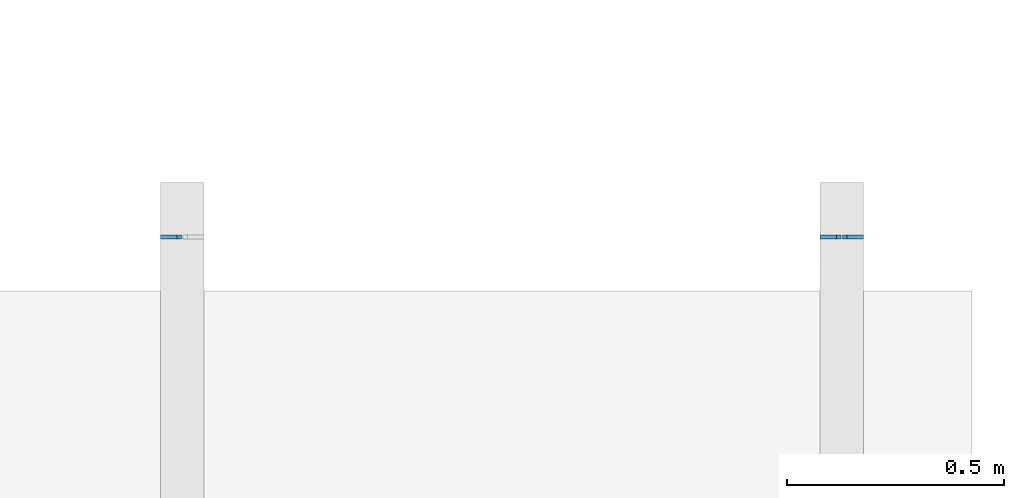
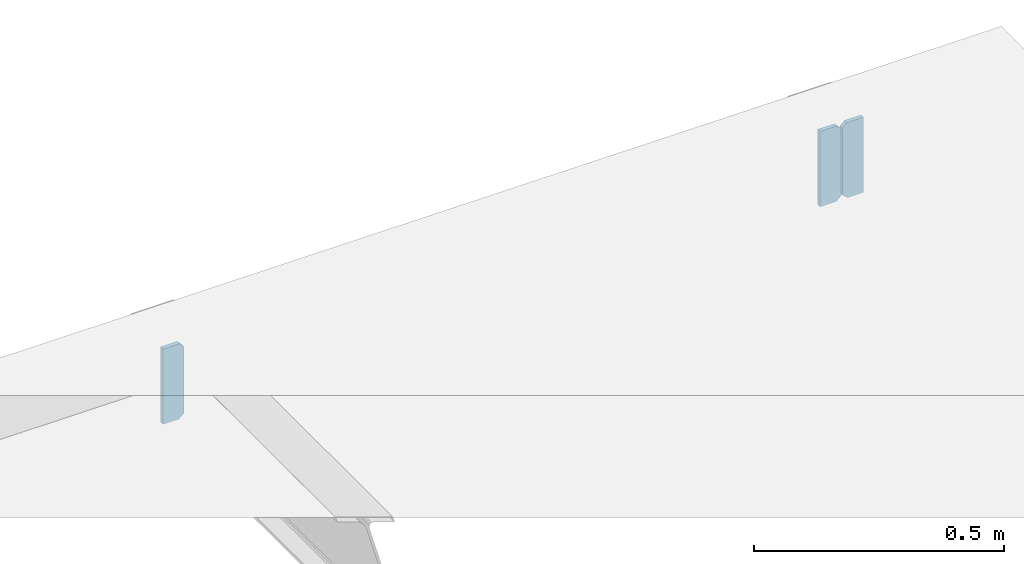
# One storey, part 6 of 7: 3 beams.
"""IFC2X3 building model written with IfcOpenShell, lengths in millimetres."""

from ifc_helpers import new_model, entity, si_unit, converted_unit, derived_unit, money_unit, direction, frame, origin_with_axes, place, context, subcontext, project, spatial, faceted_brep, material, type_object, element, save


model = new_model("IFC2X3")

# Units and contexts
model_context = context("Model", 3, precision=1e-05, world=origin_with_axes(), true_north=direction((0.0, 1.0)))
body_context = subcontext(model_context, "Body", "Model", "MODEL_VIEW", scale=1.0)
ifc_project = project(units=[si_unit("LENGTHUNIT", "METRE", prefix="MILLI"), si_unit("AREAUNIT", "SQUARE_METRE"), si_unit("VOLUMEUNIT", "CUBIC_METRE"), si_unit("ABSORBEDDOSEUNIT", "GRAY"), si_unit("AMOUNTOFSUBSTANCEUNIT", "MOLE"), si_unit("DOSEEQUIVALENTUNIT", "SIEVERT"), si_unit("ELECTRICCAPACITANCEUNIT", "FARAD"), si_unit("ELECTRICCHARGEUNIT", "COULOMB"), si_unit("ELECTRICCONDUCTANCEUNIT", "SIEMENS"), si_unit("ELECTRICCURRENTUNIT", "AMPERE"), si_unit("ELECTRICRESISTANCEUNIT", "OHM"), si_unit("ELECTRICVOLTAGEUNIT", "VOLT"), si_unit("ENERGYUNIT", "JOULE"), si_unit("FORCEUNIT", "NEWTON"), si_unit("FREQUENCYUNIT", "HERTZ"), si_unit("ILLUMINANCEUNIT", "LUX"), si_unit("INDUCTANCEUNIT", "HENRY"), si_unit("LUMINOUSFLUXUNIT", "LUMEN"), si_unit("LUMINOUSINTENSITYUNIT", "CANDELA"), si_unit("MAGNETICFLUXDENSITYUNIT", "TESLA"), si_unit("MAGNETICFLUXUNIT", "WEBER"), si_unit("MASSUNIT", "GRAM"), converted_unit("PLANEANGLEUNIT", "degree", entity("IfcReal", 0.0174532925199433), si_unit("PLANEANGLEUNIT", "RADIAN"), dimensions=[0, 0, 0, 0, 0, 0, 0]), si_unit("POWERUNIT", "WATT"), si_unit("PRESSUREUNIT", "PASCAL"), si_unit("RADIOACTIVITYUNIT", "BECQUEREL"), si_unit("SOLIDANGLEUNIT", "STERADIAN"), si_unit("THERMODYNAMICTEMPERATUREUNIT", "KELVIN"), si_unit("TIMEUNIT", "SECOND"), derived_unit("ACCELERATIONUNIT", [(si_unit("LENGTHUNIT", "METRE", prefix="MILLI"), 1), (si_unit("TIMEUNIT", "SECOND"), -2)]), derived_unit("ANGULARVELOCITYUNIT", [(converted_unit("PLANEANGLEUNIT", "degree", entity("IfcReal", 0.0174532925199433), si_unit("PLANEANGLEUNIT", "RADIAN"), dimensions=[0, 0, 0, 0, 0, 0, 0]), 1), (si_unit("TIMEUNIT", "SECOND"), -1)]), derived_unit("CURVATUREUNIT", [(converted_unit("PLANEANGLEUNIT", "degree", entity("IfcReal", 0.0174532925199433), si_unit("PLANEANGLEUNIT", "RADIAN"), dimensions=[0, 0, 0, 0, 0, 0, 0]), 1), (si_unit("LENGTHUNIT", "METRE", prefix="MILLI"), -1)]), derived_unit("DYNAMICVISCOSITYUNIT", [(si_unit("PRESSUREUNIT", "PASCAL"), 1), (si_unit("TIMEUNIT", "SECOND"), 1)]), derived_unit("HEATFLUXDENSITYUNIT", [(si_unit("POWERUNIT", "WATT"), 1), (si_unit("LENGTHUNIT", "METRE", prefix="MILLI"), -2)]), derived_unit("HEATINGVALUEUNIT", [(si_unit("ENERGYUNIT", "JOULE"), 1), (si_unit("MASSUNIT", "GRAM"), -1)]), derived_unit("INTEGERCOUNTRATEUNIT", [(si_unit("TIMEUNIT", "SECOND"), -1)]), derived_unit("IONCONCENTRATIONUNIT", [(si_unit("MASSUNIT", "GRAM"), 1), (si_unit("VOLUMEUNIT", "CUBIC_METRE"), -1)]), derived_unit("ISOTHERMALMOISTURECAPACITYUNIT", [(si_unit("VOLUMEUNIT", "CUBIC_METRE"), 1), (si_unit("MASSUNIT", "GRAM"), -1)]), derived_unit("KINEMATICVISCOSITYUNIT", [(si_unit("AREAUNIT", "SQUARE_METRE"), 1), (si_unit("TIMEUNIT", "SECOND"), -1)]), derived_unit("LINEARFORCEUNIT", [(si_unit("FORCEUNIT", "NEWTON"), 1), (si_unit("LENGTHUNIT", "METRE", prefix="MILLI"), -1)]), derived_unit("LINEARMOMENTUNIT", [(si_unit("FORCEUNIT", "NEWTON"), 1), (si_unit("LENGTHUNIT", "METRE", prefix="MILLI"), -1)]), derived_unit("LINEARSTIFFNESSUNIT", [(si_unit("FORCEUNIT", "NEWTON"), 1), (si_unit("LENGTHUNIT", "METRE", prefix="MILLI"), -1)]), derived_unit("LINEARVELOCITYUNIT", [(si_unit("LENGTHUNIT", "METRE", prefix="MILLI"), 1), (si_unit("TIMEUNIT", "SECOND"), -1)]), derived_unit("LUMINOUSINTENSITYDISTRIBUTIONUNIT", [(si_unit("LUMINOUSINTENSITYUNIT", "CANDELA"), 1), (si_unit("LUMINOUSFLUXUNIT", "LUMEN"), -1)]), derived_unit("MASSDENSITYUNIT", [(si_unit("MASSUNIT", "GRAM"), 1), (si_unit("VOLUMEUNIT", "CUBIC_METRE"), -1)]), derived_unit("MASSFLOWRATEUNIT", [(si_unit("MASSUNIT", "GRAM"), 1), (si_unit("TIMEUNIT", "SECOND"), -1)]), derived_unit("MASSPERLENGTHUNIT", [(si_unit("MASSUNIT", "GRAM"), 1), (si_unit("LENGTHUNIT", "METRE", prefix="MILLI"), -1)]), derived_unit("MODULUSOFELASTICITYUNIT", [(si_unit("FORCEUNIT", "NEWTON"), 1), (si_unit("AREAUNIT", "SQUARE_METRE"), -1)]), derived_unit("MODULUSOFLINEARSUBGRADEREACTIONUNIT", [(si_unit("FORCEUNIT", "NEWTON"), 1), (si_unit("LENGTHUNIT", "METRE", prefix="MILLI"), -2)]), derived_unit("MODULUSOFROTATIONALSUBGRADEREACTIONUNIT", [(si_unit("FORCEUNIT", "NEWTON"), 1), (si_unit("LENGTHUNIT", "METRE", prefix="MILLI"), 1)]), derived_unit("MODULUSOFSUBGRADEREACTIONUNIT", [(si_unit("FORCEUNIT", "NEWTON"), 1), (si_unit("VOLUMEUNIT", "CUBIC_METRE"), -1)]), derived_unit("MOISTUREDIFFUSIVITYUNIT", [(si_unit("VOLUMEUNIT", "CUBIC_METRE"), 1), (si_unit("TIMEUNIT", "SECOND"), -1)]), derived_unit("MOLECULARWEIGHTUNIT", [(si_unit("MASSUNIT", "GRAM"), 1), (si_unit("AMOUNTOFSUBSTANCEUNIT", "MOLE"), -1)]), derived_unit("PLANARFORCEUNIT", [(si_unit("FORCEUNIT", "NEWTON"), 1), (si_unit("LENGTHUNIT", "METRE", prefix="MILLI"), -2)]), derived_unit("ROTATIONALFREQUENCYUNIT", [(si_unit("TIMEUNIT", "SECOND"), -1)]), derived_unit("ROTATIONALMASSUNIT", [(si_unit("MASSUNIT", "GRAM"), 1), (si_unit("LENGTHUNIT", "METRE", prefix="MILLI"), 2)]), derived_unit("ROTATIONALSTIFFNESSUNIT", [(si_unit("FORCEUNIT", "NEWTON"), 1), (si_unit("LENGTHUNIT", "METRE", prefix="MILLI"), 1), (converted_unit("PLANEANGLEUNIT", "degree", entity("IfcReal", 0.0174532925199433), si_unit("PLANEANGLEUNIT", "RADIAN"), dimensions=[0, 0, 0, 0, 0, 0, 0]), -1)]), derived_unit("SECTIONAREAINTEGRALUNIT", [(si_unit("LENGTHUNIT", "METRE", prefix="MILLI"), 5)]), derived_unit("SECTIONMODULUSUNIT", [(si_unit("LENGTHUNIT", "METRE", prefix="MILLI"), 3)]), derived_unit("SHEARMODULUSUNIT", [(si_unit("FORCEUNIT", "NEWTON"), 1), (si_unit("AREAUNIT", "SQUARE_METRE"), -1)]), derived_unit("SOUNDPOWERUNIT", [(si_unit("ENERGYUNIT", "JOULE"), 1), (si_unit("TIMEUNIT", "SECOND"), -1)]), derived_unit("SPECIFICHEATCAPACITYUNIT", [(si_unit("FORCEUNIT", "NEWTON"), 1), (si_unit("MASSUNIT", "GRAM"), -1), (si_unit("THERMODYNAMICTEMPERATUREUNIT", "KELVIN"), -1)]), derived_unit("TEMPERATUREGRADIENTUNIT", [(si_unit("THERMODYNAMICTEMPERATUREUNIT", "KELVIN"), 1), (si_unit("LENGTHUNIT", "METRE", prefix="MILLI"), -1)]), derived_unit("THERMALADMITTANCEUNIT", [(si_unit("POWERUNIT", "WATT"), 1), (si_unit("AREAUNIT", "SQUARE_METRE"), -1), (si_unit("THERMODYNAMICTEMPERATUREUNIT", "KELVIN"), -1)]), derived_unit("THERMALCONDUCTANCEUNIT", [(si_unit("POWERUNIT", "WATT"), 1), (si_unit("LENGTHUNIT", "METRE", prefix="MILLI"), -1), (si_unit("THERMODYNAMICTEMPERATUREUNIT", "KELVIN"), -1)]), derived_unit("THERMALEXPANSIONCOEFFICIENTUNIT", [(si_unit("THERMODYNAMICTEMPERATUREUNIT", "KELVIN"), -1)]), derived_unit("THERMALRESISTANCEUNIT", [(si_unit("AREAUNIT", "SQUARE_METRE"), 1), (si_unit("POWERUNIT", "WATT"), -1)]), derived_unit("THERMALTRANSMITTANCEUNIT", [(si_unit("POWERUNIT", "WATT"), 1), (si_unit("AREAUNIT", "SQUARE_METRE"), -1), (si_unit("THERMODYNAMICTEMPERATUREUNIT", "KELVIN"), -1)]), derived_unit("TORQUEUNIT", [(si_unit("FORCEUNIT", "NEWTON"), 1), (si_unit("LENGTHUNIT", "METRE", prefix="MILLI"), 1)]), derived_unit("VAPORPERMEABILITYUNIT", [(si_unit("MASSUNIT", "GRAM"), 1), (si_unit("TIMEUNIT", "SECOND"), -1)]), derived_unit("VOLUMETRICFLOWRATEUNIT", [(si_unit("VOLUMEUNIT", "CUBIC_METRE"), 1), (si_unit("TIMEUNIT", "SECOND"), -1)]), derived_unit("WARPINGCONSTANTUNIT", [(si_unit("LENGTHUNIT", "METRE", prefix="MILLI"), 6)]), derived_unit("WARPINGMOMENTUNIT", [(si_unit("FORCEUNIT", "NEWTON"), 1), (si_unit("LENGTHUNIT", "METRE", prefix="MILLI"), 2)]), money_unit("USD")], contexts=[model_context])

# Site, building, storey
site_placement = place(None, origin_with_axes())
site = spatial("IfcSite", under=ifc_project, at=site_placement, CompositionType="ELEMENT")
building_placement = place(site_placement, origin_with_axes())
building = spatial("IfcBuilding", under=site, at=building_placement, Name="1", CompositionType="ELEMENT")
storey_placement = place(building_placement, frame((0.0, 0.0, -4900.0), z_axis=(0.0, 0.0, 1.0), x_axis=(1.0, 0.0, 0.0)))
storey = spatial("IfcBuildingStorey", under=building, at=storey_placement, Name="-2", CompositionType="ELEMENT", Elevation=-4900.0)

# Beams
ifc_material = material()
beam_type = type_object("IfcBeamType", PredefinedType="BEAM")
placement = place(storey_placement, frame((0.0, 0.0, 4900.0), z_axis=(0.0, 0.0, 1.0), x_axis=(1.0, 0.0, 0.0)))
element("IfcBeam", 1, at=placement, inside=storey, type_object=beam_type, material=ifc_material, context=body_context, shape_type="Brep", body=[
    faceted_brep([(14072.0, 9930.0, -1392.0), (14083.0, 9930.0, -1382.0), (14083.0, 9930.0, -1218.0), (14073.0, 9930.0, -1208.0), (14035.0, 9930.0, -1208.0), (14035.0, 9930.0, -1392.0), (14083.0, 9940.0, -1382.0), (14072.0, 9940.0, -1392.0), (14035.0, 9940.0, -1392.0), (14035.0, 9940.0, -1208.0), (14073.0, 9940.0, -1208.0), (14083.0, 9940.0, -1218.0)], [[[0, 1, 2, 3, 4, 5]], [[6, 7, 8, 9, 10, 11]], [[0, 5, 8, 7]], [[3, 10, 9, 4]], [[9, 8, 5, 4]], [[7, 6, 1, 0]], [[6, 11, 2, 1]], [[11, 10, 3, 2]]]),
])
element("IfcBeam", 2, at=placement, inside=storey, type_object=beam_type, material=ifc_material, context=body_context, shape_type="Brep", body=[
    faceted_brep([(15607.0, 9930.0, -1382.0), (15618.0, 9930.0, -1392.0), (15655.0, 9930.0, -1392.0), (15655.0, 9930.0, -1208.0), (15617.0, 9930.0, -1208.0), (15607.0, 9930.0, -1218.0), (15618.0, 9940.0, -1392.0), (15607.0, 9940.0, -1382.0), (15607.0, 9940.0, -1218.0), (15617.0, 9940.0, -1208.0), (15655.0, 9940.0, -1208.0), (15655.0, 9940.0, -1392.0)], [[[0, 1, 2, 3, 4, 5]], [[6, 7, 8, 9, 10, 11]], [[3, 2, 11, 10]], [[6, 11, 2, 1]], [[9, 4, 3, 10]], [[8, 7, 0, 5]], [[7, 6, 1, 0]], [[9, 8, 5, 4]]]),
])
element("IfcBeam", 3, at=placement, inside=storey, type_object=beam_type, material=ifc_material, context=body_context, shape_type="Brep", body=[
    faceted_brep([(15592.0, 9930.0, -1392.0), (15603.0, 9930.0, -1382.0), (15603.0, 9930.0, -1218.0), (15593.0, 9930.0, -1208.0), (15555.0, 9930.0, -1208.0), (15555.0, 9930.0, -1392.0), (15603.0, 9940.0, -1382.0), (15592.0, 9940.0, -1392.0), (15555.0, 9940.0, -1392.0), (15555.0, 9940.0, -1208.0), (15593.0, 9940.0, -1208.0), (15603.0, 9940.0, -1218.0)], [[[0, 1, 2, 3, 4, 5]], [[6, 7, 8, 9, 10, 11]], [[0, 5, 8, 7]], [[3, 10, 9, 4]], [[9, 8, 5, 4]], [[7, 6, 1, 0]], [[6, 11, 2, 1]], [[11, 10, 3, 2]]]),
])

save(model, "model.ifc")
